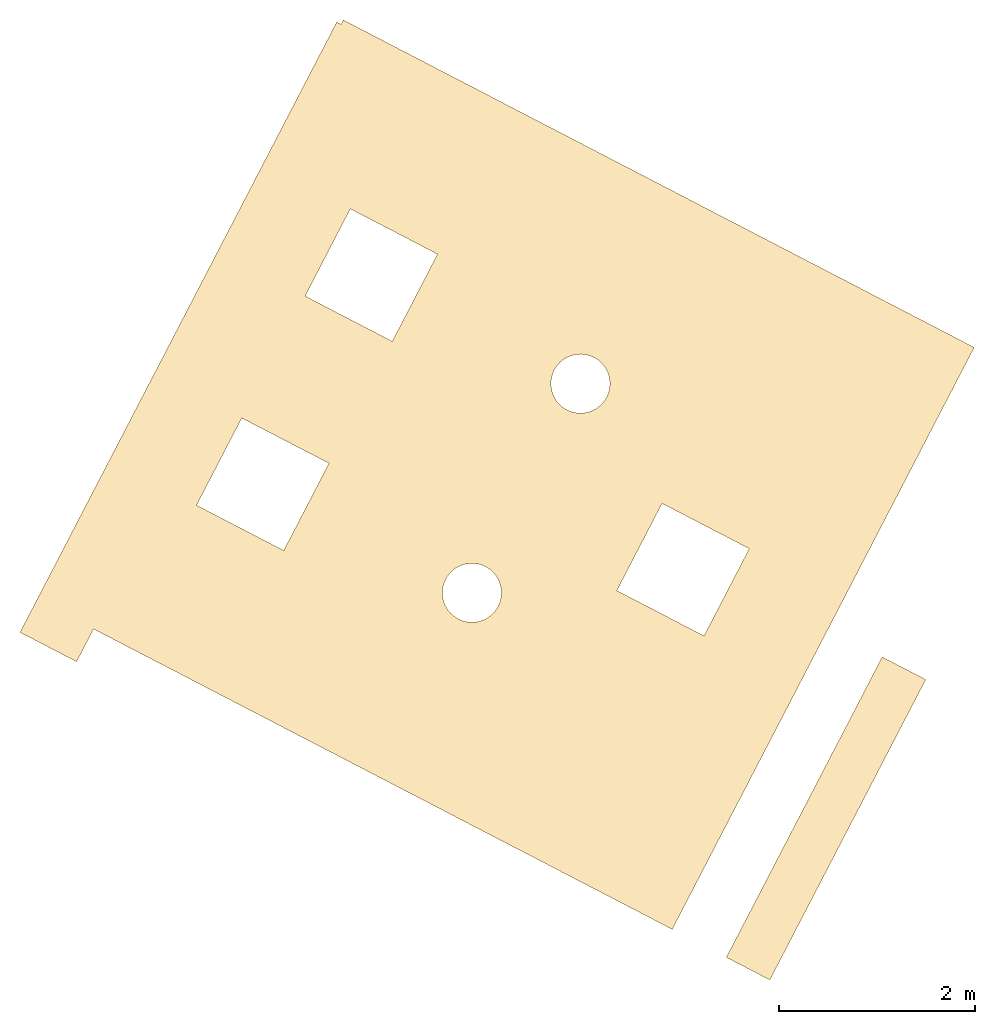
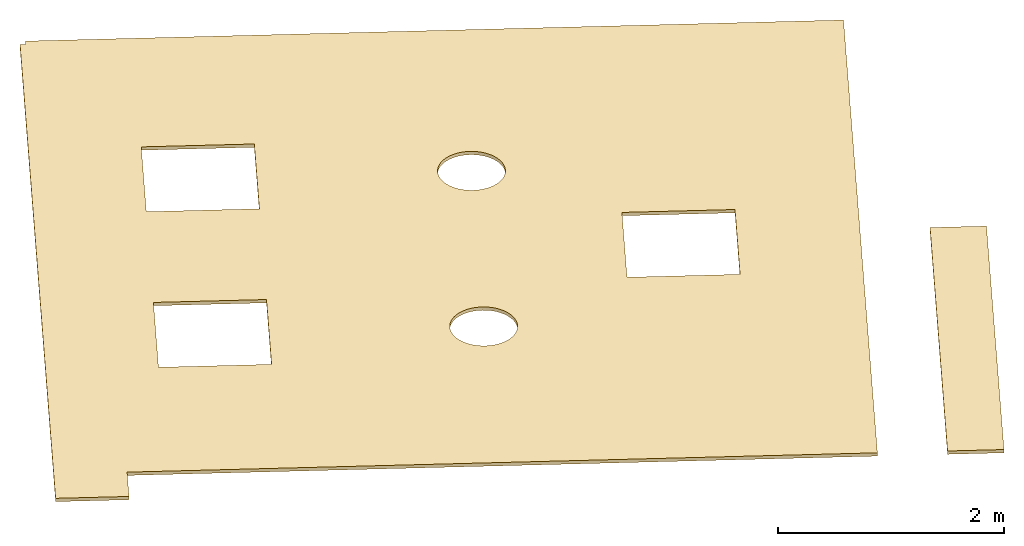
# One storey: 1 covering.
"""IFC4 building model written with IfcOpenShell, lengths in millimetres."""

from ifc_helpers import new_model, entity, si_unit, converted_unit, direction, frame, origin, place, context, subcontext, project, spatial, arc, indexed_curve, outline, extrude, material, constituent, constituent_set, type_object, element, save


model = new_model("IFC4")

# Units and contexts
model_context = context("Model", 3, precision=0.01, world=origin(), true_north=direction((6.123031769111886e-17, 1.0)))
body_context = subcontext(model_context, "Body", "Model", "MODEL_VIEW")
ifc_project = project(units=[si_unit("LENGTHUNIT", "METRE", prefix="MILLI"), si_unit("AREAUNIT", "SQUARE_METRE"), converted_unit("PLANEANGLEUNIT", "DEGREE", entity("IfcPlaneAngleMeasure", 0.017453292519943278), si_unit("PLANEANGLEUNIT", "RADIAN"), dimensions=[0, 0, 0, 0, 0, 0, 0]), si_unit("VOLUMEUNIT", "CUBIC_METRE")], contexts=[model_context])

# Site, building, storey
site_placement = place(None, frame((95732.50653529991, 169206.23203511967, 0.0), z_axis=(0.0, 0.0, 1.0), x_axis=(0.8876011022806229, -0.460612942968631, 0.0)))
site = spatial("IfcSite", under=ifc_project, at=site_placement, CompositionType="ELEMENT")
building_placement = place(site_placement, origin())
building = spatial("IfcBuilding", under=site, at=building_placement, Name="D0", CompositionType="ELEMENT")
storey_placement = place(building_placement, frame((0.0, 0.0, 138000.0)))
storey = spatial("IfcBuildingStorey", under=building, at=storey_placement, Name="02", CompositionType="ELEMENT", Elevation=138000.00000000003)

# Covering
ifc_material_1 = material(Name="_Luft", Category="Glass")
ifc_constituent_1 = constituent(ifc_material_1, Name="_Luft (2)", Category="Glass")
ifc_material_2 = material(Name="Gips")
ifc_constituent_2 = constituent(ifc_material_2, Name="Gips (2)")
ifc_constituent_set = constituent_set(constituents=[ifc_constituent_1, ifc_constituent_2])
covering_type = type_object("IfcCoveringType", PredefinedType="CEILING")
covering_placement = place(storey_placement, origin())
element("IfcCovering", 1, at=covering_placement, inside=storey, type_object=covering_type, material=ifc_constituent_set, Name="004.01", PredefinedType="CEILING", context=body_context, shape_type="SweptSolid", body=[
    extrude(outline(indexed_curve([(-3122.296025263304, 2527.0833333159744), (-3122.2960252632865, 1752.0833333643252), (-3122.2960252632865, -4252.916666668043), (-3122.296025263304, -4712.916666636076), (107.70397473636035, -4712.916666636076), (3555.218255549685, -4712.916666636076), (3555.2182555496634, 1927.0833333159549), (3930.2099068377706, 1927.0833333159549), (3930.2099068377665, 2577.0833333159803), (3555.2182555496634, 2577.0833333159803), (-3072.2972270038645, 2577.0833333159717), (-3072.2972270038645, 2527.0833333159744), (-3122.296025263304, 2527.0833333159744)], self_intersect=False), holes=[indexed_curve([(-447.2805401211718, 577.0833333640812), (-1447.2666621505912, 577.0833333640812), (-1447.2666621505912, 1577.0833333134356), (-447.2805401211718, 1577.0833333134356), (-447.2805401211718, 577.0833333640812)], self_intersect=False), indexed_curve([(752.7194598785554, -3622.916666635943), (-247.28054012140785, -3622.916666635943), (-247.28054012140785, -2622.9166666359015), (752.7194598785554, -2622.9166666359106), (752.7194598785554, -3622.916666635943)], self_intersect=False), indexed_curve([(952.7194598788391, 577.0833333641158), (952.7194598788391, 1577.0833333134356), (1952.7194598788717, 1577.0833333134356), (1952.7194598788674, 577.0833333641158), (952.7194598788391, 577.0833333641158)], self_intersect=False), indexed_curve([(-1247.2817444502757, -1322.9166666865722), (-947.2817444502747, -1022.9166666865711), (-647.2817444502735, -1322.9166666865722), (-947.2817444502747, -1622.9166666865733)], segments=[arc(1, 2, 3), arc(3, 4, 1)], self_intersect=False), indexed_curve([(1152.718255549759, -1322.9166666865722), (1452.7182555497602, -1022.9166666865711), (1752.7182555497611, -1322.9166666865722), (1452.7182555497602, -1622.9166666865733)], segments=[arc(1, 2, 3), arc(3, 4, 1)], self_intersect=False)]), frame((57377.08333331597, 40527.70397473583, 4557.0), z_axis=(0.0, 0.0, -1.0), x_axis=(0.0, -1.0, 0.0)), (0.0, 0.0, -1.0), 22.99999999999477),
    extrude(outline(indexed_curve([(-250.00000002397417, -1723.7571404066646), (250.0000000239828, -1723.7571404066646), (250.0000000239828, 1723.7571404066557), (-250.00000002397417, 1723.7571404066557), (-250.00000002397417, -1723.7571404066646)], self_intersect=False)), frame((62959.99999997602, 38696.24285959281, 4557.0)), (0.0, 0.0, 1.0), 22.99999999999477),
    extrude(outline(indexed_curve([(-1723.7571404066646, -250.0000000239828), (1723.7571404066603, -250.0000000239828), (1723.7571404066603, 250.00000002397417), (-1723.7571404066646, 250.00000002397417), (-1723.7571404066646, -250.0000000239828)], self_intersect=False)), frame((62959.999999976026, 38696.2428595928, 4544.499999999998), z_axis=(0.0, 0.0, 1.0), x_axis=(0.0, -1.0, 0.0)), (0.0, 0.0, 1.0), 12.500000000005821),
    extrude(outline(indexed_curve([(1752.0833333644123, -3122.296025263256), (2527.0833333160617, -3122.296025263256), (2527.0833333160604, -3072.2972270038167), (2577.0833333160576, -3072.2972270038154), (2577.083333315918, 3555.218255549712), (2577.08333331591, 3930.2099068378193), (1927.0833333158841, 3930.209906837805), (1927.0833333158926, 3555.218255549698), (-4712.91666663613, 3555.2182555495706), (-4712.916666636062, 107.70397473624634), (-4712.916666635989, -3122.296025263418), (-4252.916666667956, -3122.2960252633907), (1752.0833333644123, -3122.296025263256)], self_intersect=False), holes=[indexed_curve([(577.0833333641309, -1447.2666621505869), (577.0833333641085, -447.2805401211675), (1577.0833333134628, -447.28054012114524), (1577.0833333134854, -1447.2666621505646), (577.0833333641309, -1447.2666621505869)], self_intersect=False), indexed_curve([(-3622.9166666359115, -247.2805401214975), (-3622.916666635934, 752.7194598784657), (-2622.916666635901, 752.7194598784881), (-2622.9166666358788, -247.28054012147516), (-3622.9166666359115, -247.2805401214975)], self_intersect=False), indexed_curve([(1577.0833333134315, 952.7194598788657), (577.0833333641118, 952.7194598788433), (577.0833333640895, 1952.719459878876), (1577.0833333134092, 1952.7194598788983), (1577.0833333134315, 952.7194598788657)], self_intersect=False), indexed_curve([(-1322.9166666865406, -647.2817444503117), (-1022.9166666865327, -947.2817444503062), (-1322.916666686527, -1247.281744450314), (-1622.9166666865349, -947.2817444503196)], segments=[arc(1, 2, 3), arc(3, 4, 1)], self_intersect=False), indexed_curve([(-1322.9166666865942, 1752.7182555497232), (-1022.9166666865863, 1452.7182555497288), (-1322.9166666865806, 1152.7182555497209), (-1622.9166666865885, 1452.7182555497152)], segments=[arc(1, 2, 3), arc(3, 4, 1)], self_intersect=False)]), frame((57377.08333331599, 40527.703974735814, 4544.5000000000155), z_axis=(0.0, 0.0, 1.0), x_axis=(-1.0, 0.0, 0.0)), (0.0, 0.0, 1.0), 12.500000000005821),
])

save(model, "model.ifc")
